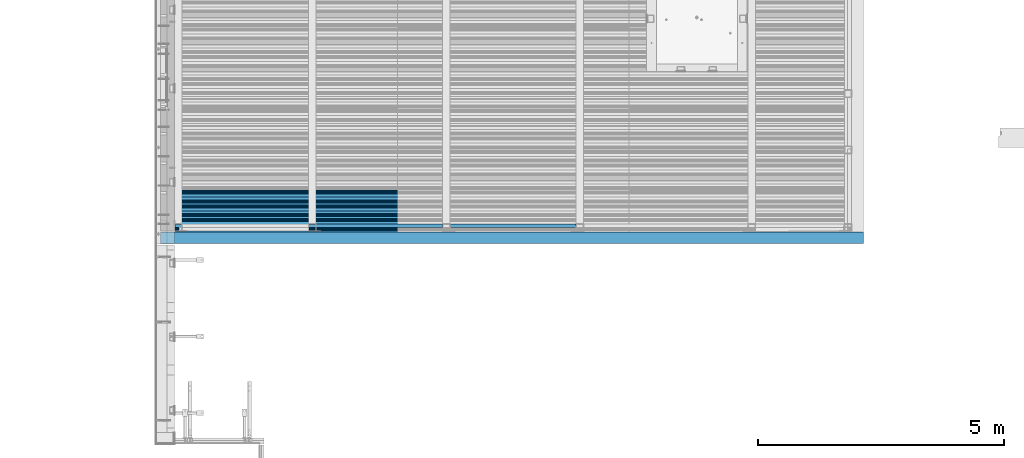
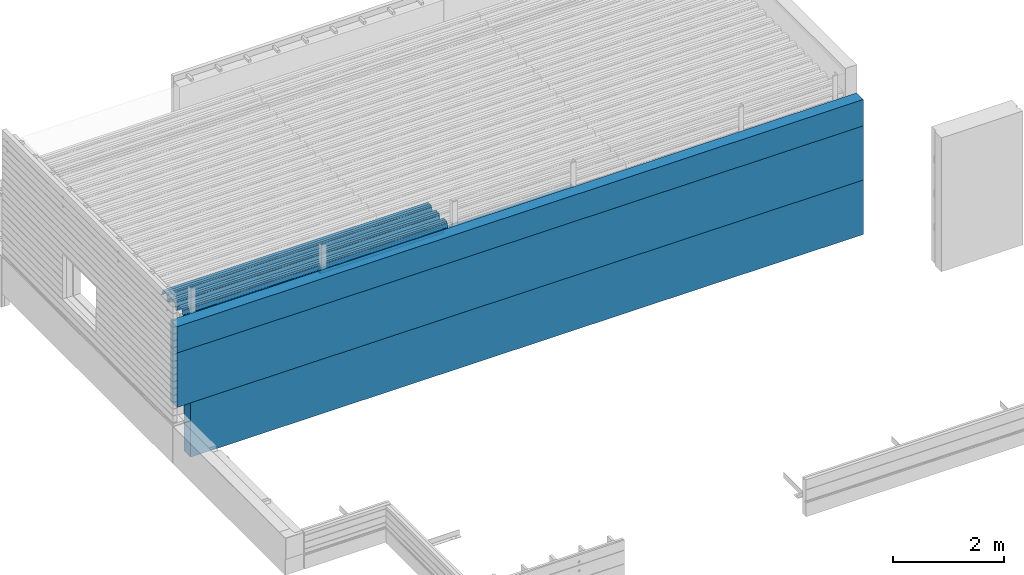
# One storey, part 18 of 153: 6 beams, 6 elements without a shape of their own.
"""IFC2X3 building model written with IfcOpenShell, lengths in millimetres."""

from ifc_helpers import new_model, si_unit, frame, origin_with_axes, place, context, subcontext, project, spatial, faceted_brep, material, type_object, element, aggregate, save


model = new_model("IFC2X3")

# Units and contexts
model_context = context("Model", 3, precision=1e-05, world=origin_with_axes())
body_context = subcontext(model_context, "Body", "Model", "MODEL_VIEW")
ifc_project = project(units=[si_unit("LENGTHUNIT", "METRE", prefix="MILLI"), si_unit("AREAUNIT", "SQUARE_METRE"), si_unit("VOLUMEUNIT", "CUBIC_METRE"), si_unit("MASSUNIT", "GRAM", prefix="KILO"), si_unit("TIMEUNIT", "SECOND"), si_unit("PLANEANGLEUNIT", "RADIAN"), si_unit("SOLIDANGLEUNIT", "STERADIAN"), si_unit("THERMODYNAMICTEMPERATUREUNIT", "DEGREE_CELSIUS"), si_unit("LUMINOUSINTENSITYUNIT", "LUMEN")], contexts=[model_context])

# Site, building, storey
site_placement = place(None, origin_with_axes())
site = spatial("IfcSite", under=ifc_project, at=site_placement, CompositionType="ELEMENT")
building_placement = place(site_placement, origin_with_axes())
building = spatial("IfcBuilding", under=site, at=building_placement, CompositionType="ELEMENT")
storey_placement = place(building_placement, origin_with_axes())
storey = spatial("IfcBuildingStorey", under=building, at=storey_placement, Name="8", CompositionType="ELEMENT", Elevation=0.0)

# Assembly, beam
assembly_1_placement = place(storey_placement, origin_with_axes())
assembly_1 = element("IfcElementAssembly", 1, at=assembly_1_placement, inside=storey, Name="Steel Assembly", AssemblyPlace="NOTDEFINED", PredefinedType="RIGID_FRAME")
ifc_material_1 = material(Name="STEEL/S355J2")
beam_type_1 = type_object("IfcBeamType", Name="80X80X4", PredefinedType="NOTDEFINED")
beam_1_placement = place(assembly_1_placement, frame((13610.0, 15090.0, 105625.0), z_axis=(0.0, 0.0, 1.0), x_axis=(1.0, 0.0, 0.0)))
beam_1 = element("IfcBeam", 2, at=beam_1_placement, type_object=beam_type_1, material=ifc_material_1, ObjectType="80X80X4", context=body_context, shape_type="Brep", body=[
    faceted_brep([(0.0, 36.0, -36.0), (0.0, -36.0, -36.0), (2567.0, -36.0, -36.0), (2567.0, 36.0, -36.0), (0.0, -36.0, 36.0), (2567.0, -36.0, 36.0), (0.0, 36.0, 36.0), (2567.0, 36.0, 36.0), (0.0, 40.0, -40.0), (0.0, 40.0, 40.0), (2567.0, 40.0, 40.0), (2567.0, 40.0, -40.0), (0.0, -40.0, 40.0), (2567.0, -40.0, 40.0), (0.0, -40.0, -40.0), (2567.0, -40.0, -40.0)], [[[0, 1, 2, 3]], [[1, 4, 5, 2]], [[4, 6, 7, 5]], [[6, 0, 3, 7]], [[8, 9, 10, 11]], [[9, 12, 13, 10]], [[12, 14, 15, 13]], [[14, 8, 11, 15]], [[13, 15, 11, 10], [5, 7, 3, 2]], [[14, 12, 9, 8], [6, 4, 1, 0]]]),
])
aggregate(assembly_1, [beam_1])

assembly_2_placement = place(storey_placement, origin_with_axes())
assembly_2 = element("IfcElementAssembly", 3, at=assembly_2_placement, inside=storey, Name="Steel Assembly", AssemblyPlace="NOTDEFINED", PredefinedType="RIGID_FRAME")
beam_2_placement = place(assembly_2_placement, frame((10880.0, 15090.0, 105625.0), z_axis=(0.0, 0.0, 1.0), x_axis=(1.0, 0.0, 0.0)))
beam_2 = element("IfcBeam", 4, at=beam_2_placement, type_object=beam_type_1, material=ifc_material_1, ObjectType="80X80X4", context=body_context, shape_type="Brep", body=[
    faceted_brep([(0.0, 36.0, -36.0), (0.0, -36.0, -36.0), (2580.0, -36.0, -36.0), (2580.0, 36.0, -36.0), (0.0, -36.0, 36.0), (2580.0, -36.0, 36.0), (0.0, 36.0, 36.0), (2580.0, 36.0, 36.0), (0.0, 40.0, -40.0), (0.0, 40.0, 40.0), (2580.0, 40.0, 40.0), (2580.0, 40.0, -40.0), (0.0, -40.0, 40.0), (2580.0, -40.0, 40.0), (0.0, -40.0, -40.0), (2580.0, -40.0, -40.0)], [[[0, 1, 2, 3]], [[1, 4, 5, 2]], [[4, 6, 7, 5]], [[6, 0, 3, 7]], [[8, 9, 10, 11]], [[9, 12, 13, 10]], [[12, 14, 15, 13]], [[14, 8, 11, 15]], [[13, 15, 11, 10], [5, 7, 3, 2]], [[14, 12, 9, 8], [6, 4, 1, 0]]]),
])
aggregate(assembly_2, [beam_2])

assembly_3_placement = place(storey_placement, origin_with_axes())
assembly_3 = element("IfcElementAssembly", 5, at=assembly_3_placement, inside=storey, Name="Steel Assembly", AssemblyPlace="NOTDEFINED", PredefinedType="RIGID_FRAME")
beam_type_2 = type_object("IfcBeamType", Name="W", PredefinedType="NOTDEFINED")
beam_3_placement = place(assembly_3_placement, frame((13534.9999999929, 15385.2090542281, 105749.900488359), z_axis=(0.0, -0.0124990270013869, 0.999921884110963), x_axis=(-1.0, 3.00000001838171e-08, 0.0)))
beam_3 = element("IfcBeam", 6, at=beam_3_placement, type_object=beam_type_2, material=ifc_material_1, ObjectType="W", context=body_context, shape_type="Brep", body=[
    faceted_brep([(0.0, -412.839996337891, -77.0100021362159), (0.0, -409.160003662109, -77.0100021362014), (5530.0, -409.160003662109, -77.0100021362014), (5530.0, -412.839996337891, -77.0100021362159), (0.0, -408.070007324222, -73.4800033569045), (5530.0, -408.070007324222, -73.4800033569045), (0.0, -400.339996337894, -48.0600013732619), (5530.0, -400.339996337894, -48.0600013732619), (0.0, -399.459991455082, -46.5600013732619), (5530.0, -399.459991455082, -46.5600013732619), (0.0, -390.329986572269, -36.5499992370314), (5530.0, -390.329986572269, -36.5499992370314), (0.0, -389.19000244141, -34.6300010680861), (5530.0, -389.19000244141, -34.6300010680861), (0.0, -367.820007324222, 35.3400001526024), (5530.0, -367.820007324222, 35.3400001526024), (0.0, -366.989990234379, 36.8499984741502), (5530.0, -366.989990234379, 36.8499984741502), (0.0, -357.809997558597, 46.8600006103807), (5530.0, -357.809997558597, 46.8600006103807), (0.0, -356.720001220707, 48.7700004577782), (5530.0, -356.720001220707, 48.7700004577782), (0.0, -349.309997558594, 73.1500015258935), (5530.0, -349.309997558594, 73.1500015258935), (0.0, -347.850006103516, 75.2300033569481), (5530.0, -347.850006103516, 75.2300033569481), (0.0, -345.470001220707, 76.010002136245), (5530.0, -345.470001220707, 76.010002136245), (0.0, -305.480010986332, 76.010002136245), (5530.0, -305.480010986332, 76.010002136245), (0.0, -304.279998779301, 75.8000030517578), (5530.0, -304.279998779301, 75.8000030517578), (0.0, -291.679992675785, 71.6999969482567), (5530.0, -291.679992675785, 71.6999969482567), (0.0, -290.179992675789, 71.2300033569481), (5530.0, -290.179992675789, 71.2300033569481), (0.0, -288.720001220707, 71.6999969482567), (5530.0, -288.720001220707, 71.6999969482567), (0.0, -276.119995117191, 75.8000030517869), (5530.0, -276.119995117191, 75.8000030517869), (0.0, -274.929992675785, 76.010002136245), (5530.0, -274.929992675785, 76.010002136245), (0.0, -234.94000244141, 76.010002136245), (5530.0, -234.94000244141, 76.010002136245), (0.0, -232.550003051758, 75.2300033569627), (5530.0, -232.550003051758, 75.2300033569627), (0.0, -231.100006103519, 73.1500015258935), (5530.0, -231.100006103519, 73.1500015258935), (0.0, -223.679992675785, 48.7700004577782), (5530.0, -223.679992675785, 48.7700004577782), (0.0, -222.589996337894, 46.8600006103661), (5530.0, -222.589996337894, 46.8600006103661), (0.0, -213.410003662113, 36.8499984741502), (5530.0, -213.410003662113, 36.8499984741502), (0.0, -212.529998779301, 35.3400001526024), (5530.0, -212.529998779301, 35.3400001526024), (0.0, -191.160003662109, -34.6300010681007), (5530.0, -191.160003662109, -34.6300010681007), (0.0, -190.070007324222, -36.5499992370605), (5530.0, -190.070007324222, -36.5499992370605), (0.0, -180.940002441406, -46.560001373291), (5530.0, -180.940002441406, -46.560001373291), (0.0, -180.059997558597, -48.0600013732619), (5530.0, -180.059997558597, -48.0600013732619), (0.0, -172.330001831055, -73.480003356919), (5530.0, -172.330001831055, -73.480003356919), (0.0, -171.240005493168, -77.0100021362159), (5530.0, -171.240005493168, -77.0100021362159), (0.0, -129.330001831062, -77.0100021362014), (5530.0, -129.330001831062, -77.0100021362014), (0.0, -128.300003051761, -73.480003356919), (5530.0, -128.300003051761, -73.480003356919), (0.0, -120.51999664307, -48.0600013732765), (5530.0, -120.51999664307, -48.0600013732765), (0.0, -119.629997253418, -46.5600013732765), (5530.0, -119.629997253418, -46.5600013732765), (0.0, -110.500000000004, -36.5499992370314), (5530.0, -110.500000000004, -36.5499992370314), (0.0, -109.419998168949, -34.6300010680861), (5530.0, -109.419998168949, -34.6300010680861), (0.0, -88.0500030517615, 35.3400001526024), (5530.0, -88.0500030517615, 35.3400001526024), (0.0, -87.160003662113, 36.8499984741356), (5530.0, -87.160003662113, 36.8499984741356), (0.0, -78.0400009155273, 46.8600006103807), (5530.0, -78.0400009155273, 46.8600006103807), (0.0, -76.8899993896557, 48.7700004577782), (5530.0, -76.8899993896557, 48.7700004577782), (0.0, -69.4800033569336, 73.1500015258935), (5530.0, -69.4800033569336, 73.1500015258935), (0.0, -68.0299987793042, 75.2300033569336), (5530.0, -68.0299987793042, 75.2300033569336), (0.0, -65.6399993896521, 76.010002136245), (5530.0, -65.6399993896521, 76.010002136245), (0.0, -25.6499996185375, 76.0100021362596), (5530.0, -25.6499996185375, 76.0100021362596), (0.0, -24.5100002288891, 75.8000030517724), (5530.0, -24.5100002288891, 75.8000030517724), (0.0, -11.8500003814697, 71.6999969482567), (5530.0, -11.8500003814697, 71.6999969482567), (0.0, -10.3999996185339, 71.2300033569481), (5530.0, -10.3999996185339, 71.2300033569481), (0.0, -8.89999961853391, 71.6999969482567), (5530.0, -8.89999961853391, 71.6999969482567), (0.0, 3.71000003814333, 75.8000030517724), (5530.0, 3.71000003814333, 75.8000030517724), (0.0, 4.90000009536379, 76.0100021362596), (5530.0, 4.90000009536379, 76.0100021362596), (0.0, 44.8899993896484, 76.010002136245), (5530.0, 44.8899993896484, 76.010002136245), (0.0, 47.2799987792932, 75.2300033569481), (5530.0, 47.2799987792932, 75.2300033569481), (0.0, 48.6800003051721, 73.1500015258935), (5530.0, 48.6800003051721, 73.1500015258935), (0.0, 56.1500015258753, 48.7700004577782), (5530.0, 56.1500015258753, 48.7700004577782), (0.0, 57.2400016784632, 46.8600006103807), (5530.0, 57.2400016784632, 46.8600006103807), (0.0, 66.3700027465784, 36.8499984741211), (5530.0, 66.3700027465784, 36.8499984741211), (0.0, 67.2499999999964, 35.3400001526024), (5530.0, 67.2499999999964, 35.3400001526024), (0.0, 88.6200027465748, -34.6300010681007), (5530.0, 88.6200027465748, -34.6300010681007), (0.0, 89.709999084469, -36.549999237046), (5530.0, 89.709999084469, -36.549999237046), (0.0, 98.8899993896412, -46.5600013732765), (5530.0, 98.8899993896412, -46.5600013732765), (0.0, 99.7699966430628, -48.0600013732765), (5530.0, 99.7699966430628, -48.0600013732765), (0.0, 107.499999999996, -73.4800033569336), (5530.0, 107.499999999996, -73.4800033569336), (0.0, 108.589996337887, -77.0100021362014), (5530.0, 108.589996337887, -77.0100021362014), (0.0, 112.269996643063, -77.0100021362159), (5530.0, 112.269996643063, -77.0100021362159), (0.0, 146.759994506836, -77.0100021362159), (5530.0, 146.759994506836, -77.0100021362159), (0.0, 150.440002441403, -77.0100021362159), (5530.0, 150.440002441403, -77.0100021362159), (0.0, 151.529998779297, -73.480003356919), (5530.0, 151.529998779297, -73.480003356919), (0.0, 159.30999755859, -48.0600013732765), (5530.0, 159.30999755859, -48.0600013732765), (0.0, 160.190002441406, -46.5600013732619), (5530.0, 160.190002441406, -46.5600013732619), (0.0, 169.320007324215, -36.549999237046), (5530.0, 169.320007324215, -36.549999237046), (0.0, 170.410003662106, -34.6300010680861), (5530.0, 170.410003662106, -34.6300010680861), (0.0, 191.779998779293, 35.3400001526024), (5530.0, 191.779998779293, 35.3400001526024), (0.0, 192.660003662109, 36.8499984741502), (5530.0, 192.660003662109, 36.8499984741502), (0.0, 201.789993286129, 46.8600006103661), (5530.0, 201.789993286129, 46.8600006103661), (0.0, 202.880004882809, 48.7700004577637), (5530.0, 202.880004882809, 48.7700004577637), (0.0, 210.350006103512, 73.150001525908), (5530.0, 210.350006103512, 73.150001525908), (0.0, 211.800003051754, 75.2300033569481), (5530.0, 211.800003051754, 75.2300033569481), (0.0, 214.190002441406, 76.010002136245), (5530.0, 214.190002441406, 76.010002136245), (0.0, 254.179992675778, 76.010002136245), (5530.0, 254.179992675778, 76.010002136245), (0.0, 255.320007324215, 75.8000030517869), (5530.0, 255.320007324215, 75.8000030517869), (0.0, 267.980010986324, 71.6999969482713), (5530.0, 267.980010986324, 71.6999969482713), (0.0, 269.429992675778, 71.2300033569481), (5530.0, 269.429992675778, 71.2300033569481), (0.0, 270.880004882809, 71.6999969482567), (5530.0, 270.880004882809, 71.6999969482567), (0.0, 283.540008544918, 75.8000030517869), (5530.0, 283.540008544918, 75.8000030517869), (0.0, 284.679992675778, 76.010002136245), (5530.0, 284.679992675778, 76.010002136245), (0.0, 324.670013427731, 76.010002136245), (5530.0, 324.670013427731, 76.010002136245), (0.0, 327.049987792969, 75.2300033569627), (5530.0, 327.049987792969, 75.2300033569627), (0.0, 328.510009765625, 73.1500015258789), (5530.0, 328.510009765625, 73.1500015258789), (0.0, 335.980010986324, 48.7700004577782), (5530.0, 335.980010986324, 48.7700004577782), (0.0, 337.05999755859, 46.8600006103661), (5530.0, 337.05999755859, 46.8600006103661), (0.0, 346.190002441399, 36.8499984741356), (5530.0, 346.190002441399, 36.8499984741356), (0.0, 347.079986572266, 35.3400001526024), (5530.0, 347.079986572266, 35.3400001526024), (0.0, 368.450012207028, -34.6300010680861), (5530.0, 368.450012207028, -34.6300010680861), (0.0, 369.529998779293, -36.5499992370314), (5530.0, 369.529998779293, -36.5499992370314), (0.0, 378.660003662106, -46.5600013732619), (5530.0, 378.660003662106, -46.5600013732619), (0.0, 379.540008544918, -48.0600013732619), (5530.0, 379.540008544918, -48.0600013732619), (0.0, 387.329986572262, -73.480003356919), (5530.0, 387.329986572262, -73.480003356919), (0.0, 388.410003662109, -77.0100021362159), (5530.0, 388.410003662109, -77.0100021362159), (0.0, 392.100006103512, -77.0100021362159), (5530.0, 392.100006103512, -77.0100021362159), (0.0, 426.589996337887, -77.0100021362159), (5530.0, 426.589996337887, -77.0100021362159), (0.0, 430.269989013668, -77.0100021362159), (5530.0, 430.269989013668, -77.0100021362159), (0.0, 431.359985351559, -73.4800033569045), (5530.0, 431.359985351559, -73.4800033569045), (0.0, 433.179992675778, -67.5699996948097), (5530.0, 433.179992675778, -67.5699996948097), (0.0, 432.220001220699, -67.2699966430373), (5530.0, 432.220001220699, -67.2699966430373), (0.0, 430.410003662106, -73.1800003051612), (5530.0, 430.410003662106, -73.1800003051612), (0.0, 429.529998779293, -76.0100021362159), (5530.0, 429.529998779293, -76.0100021362159), (0.0, 426.589996337891, -76.0100021362159), (5530.0, 426.589996337891, -76.0100021362159), (0.0, 392.100006103512, -76.0100021362159), (5530.0, 392.100006103512, -76.0100021362159), (0.0, 389.149993896481, -76.0100021362014), (5530.0, 389.149993896481, -76.0100021362014), (0.0, 388.279998779293, -73.1800003051467), (5530.0, 388.279998779293, -73.1800003051467), (0.0, 380.470001220699, -47.659999847383), (5530.0, 380.470001220699, -47.659999847383), (0.0, 379.470001220699, -45.9599990844436), (5530.0, 379.470001220699, -45.9599990844436), (0.0, 370.350006103512, -35.9599990844581), (5530.0, 370.350006103512, -35.9599990844581), (0.0, 369.369995117184, -34.2299995422218), (5530.0, 369.369995117184, -34.2299995422218), (0.0, 347.999999999996, 35.7500000000146), (5530.0, 347.999999999996, 35.7500000000146), (0.0, 346.999999999996, 37.4399986267235), (5530.0, 346.999999999996, 37.4399986267235), (0.0, 337.880004882809, 47.450000762954), (5530.0, 337.880004882809, 47.450000762954), (0.0, 336.899993896481, 49.1699981689453), (5530.0, 336.899993896481, 49.1699981689453), (0.0, 329.420013427731, 73.5999984741356), (5530.0, 329.420013427731, 73.5999984741356), (0.0, 327.679992675781, 76.0699996948533), (5530.0, 327.679992675781, 76.0699996948533), (0.0, 324.829986572262, 77.010002136245), (5530.0, 324.829986572262, 77.010002136245), (0.0, 284.589996337887, 77.010002136245), (5530.0, 284.589996337887, 77.010002136245), (0.0, 283.290008544922, 76.769996643081), (5530.0, 283.290008544922, 76.769996643081), (0.0, 270.570007324215, 72.6500015258935), (5530.0, 270.570007324215, 72.6500015258935), (0.0, 269.429992675781, 72.2799987793114), (5530.0, 269.429992675781, 72.2799987793114), (0.0, 268.279998779293, 72.650001525908), (5530.0, 268.279998779293, 72.650001525908), (0.0, 255.570007324219, 76.769996643081), (5530.0, 255.570007324219, 76.769996643081), (0.0, 254.270004272461, 77.0100021362596), (5530.0, 254.270004272461, 77.0100021362596), (0.0, 214.029998779293, 77.0100021362596), (5530.0, 214.029998779293, 77.0100021362596), (0.0, 211.179992675781, 76.0699996948388), (5530.0, 211.179992675781, 76.0699996948388), (0.0, 209.440002441403, 73.5999984741356), (5530.0, 209.440002441403, 73.5999984741356), (0.0, 201.960006713864, 49.1699981689599), (5530.0, 201.960006713864, 49.1699981689599), (0.0, 200.979995727532, 47.450000762954), (5530.0, 200.979995727532, 47.450000762954), (0.0, 191.850006103508, 37.4399986267235), (5530.0, 191.850006103508, 37.4399986267235), (0.0, 190.860000610352, 35.7500000000146), (5530.0, 190.860000610352, 35.7500000000146), (0.0, 169.49000549316, -34.2299995422218), (5530.0, 169.49000549316, -34.2299995422218), (0.0, 168.509994506832, -35.9599990844581), (5530.0, 168.509994506832, -35.9599990844581), (0.0, 159.380004882805, -45.9599990844436), (5530.0, 159.380004882805, -45.9599990844436), (0.0, 158.389999389645, -47.6599998473976), (5530.0, 158.389999389645, -47.6599998473976), (0.0, 150.580001831051, -73.1800003051612), (5530.0, 150.580001831051, -73.1800003051612), (0.0, 149.710006713864, -76.0100021362159), (5530.0, 149.710006713864, -76.0100021362159), (0.0, 146.759994506836, -76.0100021362159), (5530.0, 146.759994506836, -76.0100021362159), (0.0, 112.269996643063, -76.0100021362159), (5530.0, 112.269996643063, -76.0100021362159), (0.0, 109.319999694821, -76.0100021362159), (5530.0, 109.319999694821, -76.0100021362159), (0.0, 108.449996948239, -73.1900024413917), (5530.0, 108.449996948239, -73.1900024413917), (0.0, 100.690002441406, -47.659999847383), (5530.0, 100.690002441406, -47.659999847383), (0.0, 99.6999969482386, -45.9599990844581), (5530.0, 99.6999969482386, -45.9599990844581), (0.0, 90.5199966430664, -35.9599990844581), (5530.0, 90.5199966430664, -35.9599990844581), (0.0, 89.5400009155273, -34.2299995422218), (5530.0, 89.5400009155273, -34.2299995422218), (0.0, 68.1699981689417, 35.7500000000146), (5530.0, 68.1699981689417, 35.7500000000146), (0.0, 67.1699981689417, 37.4399986267235), (5530.0, 67.1699981689417, 37.4399986267235), (0.0, 58.0499992370569, 47.4500007629686), (5530.0, 58.0499992370569, 47.4500007629686), (0.0, 57.0699996948206, 49.1699981689599), (5530.0, 57.0699996948206, 49.1699981689599), (0.0, 49.5900001525843, 73.5899963379052), (5530.0, 49.5900001525843, 73.5899963379052), (0.0, 47.9099998474085, 76.0699996948388), (5530.0, 47.9099998474085, 76.0699996948388), (0.0, 45.0499992370569, 77.010002136245), (5530.0, 45.0499992370569, 77.010002136245), (0.0, 4.82000017165774, 77.010002136245), (5530.0, 4.82000017165774, 77.010002136245), (0.0, 3.47000002860659, 76.7699966430955), (5530.0, 3.47000002860659, 76.7699966430955), (0.0, -9.19999980926514, 72.6500015258935), (5530.0, -9.19999980926514, 72.6500015258935), (0.0, -10.3900003433264, 72.2799987792969), (5530.0, -10.3900003433264, 72.2799987792969), (0.0, -11.5399999618567, 72.6500015258935), (5530.0, -11.5399999618567, 72.6500015258935), (0.0, -24.2600002288855, 76.769996643081), (5530.0, -24.2600002288855, 76.769996643081), (0.0, -25.559999465946, 77.0100021362596), (5530.0, -25.559999465946, 77.0100021362596), (0.0, -65.8000030517615, 77.0100021362596), (5530.0, -65.8000030517615, 77.0100021362596), (0.0, -68.6500015258862, 76.0699996948533), (5530.0, -68.6500015258862, 76.0699996948533), (0.0, -70.3899993896521, 73.5999984741356), (5530.0, -70.3899993896521, 73.5999984741356), (0.0, -77.8199996948242, 49.1800003051903), (5530.0, -77.8199996948242, 49.1800003051903), (0.0, -78.8399963378943, 47.450000762954), (5530.0, -78.8399963378943, 47.450000762954), (0.0, -87.9700012207031, 37.4399986267235), (5530.0, -87.9700012207031, 37.4399986267235), (0.0, -88.9700012207068, 35.7500000000146), (5530.0, -88.9700012207068, 35.7500000000146), (0.0, -110.339996337894, -34.2299995422218), (5530.0, -110.339996337894, -34.2299995422218), (0.0, -111.319999694828, -35.9599990844581), (5530.0, -111.319999694828, -35.9599990844581), (0.0, -120.440002441406, -45.9599990844436), (5530.0, -120.440002441406, -45.9599990844436), (0.0, -121.44000244141, -47.6599998473976), (5530.0, -121.44000244141, -47.6599998473976), (0.0, -129.250000000004, -73.1900024413771), (5530.0, -129.250000000004, -73.1900024413771), (0.0, -130.080001831062, -76.0100021362159), (5530.0, -130.080001831062, -76.0100021362159), (0.0, -170.5, -76.0100021362014), (5530.0, -170.5, -76.0100021362014), (0.0, -171.380004882816, -73.1900024413917), (5530.0, -171.380004882816, -73.1900024413917), (0.0, -179.139999389652, -47.6599998473976), (5530.0, -179.139999389652, -47.6599998473976), (0.0, -180.130004882816, -45.9599990844581), (5530.0, -180.130004882816, -45.9599990844581), (0.0, -189.259994506836, -35.9599990844581), (5530.0, -189.259994506836, -35.9599990844581), (0.0, -190.240005493168, -34.2299995422218), (5530.0, -190.240005493168, -34.2299995422218), (0.0, -211.610000610355, 35.7500000000146), (5530.0, -211.610000610355, 35.7500000000146), (0.0, -212.600006103519, 37.4399986267381), (5530.0, -212.600006103519, 37.4399986267381), (0.0, -221.779998779301, 47.450000762954), (5530.0, -221.779998779301, 47.450000762954), (0.0, -222.75999450684, 49.1699981689599), (5530.0, -222.75999450684, 49.1699981689599), (0.0, -230.190002441406, 73.5999984741356), (5530.0, -230.190002441406, 73.5999984741356), (0.0, -231.919998168945, 76.0699996948388), (5530.0, -231.919998168945, 76.0699996948388), (0.0, -234.779998779301, 77.010002136245), (5530.0, -234.779998779301, 77.010002136245), (0.0, -275.010009765629, 77.010002136245), (5530.0, -275.010009765629, 77.010002136245), (0.0, -276.359985351563, 76.769996643081), (5530.0, -276.359985351563, 76.769996643081), (0.0, -289.029998779297, 72.6500015258789), (5530.0, -289.029998779297, 72.6500015258789), (0.0, -290.179992675785, 72.2799987793114), (5530.0, -290.179992675785, 72.2799987793114), (0.0, -291.380004882816, 72.650001525908), (5530.0, -291.380004882816, 72.650001525908), (0.0, -304.040008544926, 76.769996643081), (5530.0, -304.040008544926, 76.769996643081), (0.0, -305.390014648441, 77.010002136245), (5530.0, -305.390014648441, 77.010002136245), (0.0, -345.63000488282, 77.0100021362596), (5530.0, -345.63000488282, 77.0100021362596), (0.0, -348.480010986332, 76.0699996948388), (5530.0, -348.480010986332, 76.0699996948388), (0.0, -350.220001220707, 73.5999984741356), (5530.0, -350.220001220707, 73.5999984741356), (0.0, -357.649993896492, 49.1699981689599), (5530.0, -357.649993896492, 49.1699981689599), (0.0, -358.63000488282, 47.450000762954), (5530.0, -358.63000488282, 47.450000762954), (0.0, -367.809997558594, 37.4300003051903), (5530.0, -367.809997558594, 37.4300003051903), (0.0, -368.750000000004, 35.7299995422654), (5530.0, -368.750000000004, 35.7299995422654), (0.0, -390.109985351566, -34.2200012207031), (5530.0, -390.109985351566, -34.2200012207031), (0.0, -391.140014648441, -35.9500007629249), (5530.0, -391.140014648441, -35.9500007629249), (0.0, -400.269989013676, -45.9599990844436), (5530.0, -400.269989013676, -45.9599990844436), (0.0, -401.269989013672, -47.6599998473976), (5530.0, -401.269989013672, -47.6599998473976), (0.0, -409.029998779297, -73.1900024413917), (5530.0, -409.029998779297, -73.1900024413917), (0.0, -409.899993896488, -76.0100021362159), (5530.0, -409.899993896488, -76.0100021362159), (0.0, -412.839996337891, -76.0100021362159), (5530.0, -412.839996337891, -76.0100021362159), (0.0, -433.179992675785, -76.0100021362159), (5530.0, -433.179992675785, -76.0100021362159), (0.0, -433.179992675785, -77.0100021362159), (5530.0, -433.179992675785, -77.0100021362159)], [[[0, 1, 2, 3]], [[1, 4, 5, 2]], [[4, 6, 7, 5]], [[6, 8, 9, 7]], [[8, 10, 11, 9]], [[10, 12, 13, 11]], [[12, 14, 15, 13]], [[14, 16, 17, 15]], [[16, 18, 19, 17]], [[18, 20, 21, 19]], [[20, 22, 23, 21]], [[22, 24, 25, 23]], [[24, 26, 27, 25]], [[26, 28, 29, 27]], [[28, 30, 31, 29]], [[30, 32, 33, 31]], [[32, 34, 35, 33]], [[34, 36, 37, 35]], [[36, 38, 39, 37]], [[38, 40, 41, 39]], [[40, 42, 43, 41]], [[42, 44, 45, 43]], [[44, 46, 47, 45]], [[46, 48, 49, 47]], [[48, 50, 51, 49]], [[50, 52, 53, 51]], [[52, 54, 55, 53]], [[54, 56, 57, 55]], [[56, 58, 59, 57]], [[58, 60, 61, 59]], [[60, 62, 63, 61]], [[62, 64, 65, 63]], [[64, 66, 67, 65]], [[66, 68, 69, 67]], [[68, 70, 71, 69]], [[70, 72, 73, 71]], [[72, 74, 75, 73]], [[74, 76, 77, 75]], [[76, 78, 79, 77]], [[78, 80, 81, 79]], [[80, 82, 83, 81]], [[82, 84, 85, 83]], [[84, 86, 87, 85]], [[86, 88, 89, 87]], [[88, 90, 91, 89]], [[90, 92, 93, 91]], [[92, 94, 95, 93]], [[94, 96, 97, 95]], [[96, 98, 99, 97]], [[98, 100, 101, 99]], [[100, 102, 103, 101]], [[102, 104, 105, 103]], [[104, 106, 107, 105]], [[106, 108, 109, 107]], [[108, 110, 111, 109]], [[110, 112, 113, 111]], [[112, 114, 115, 113]], [[114, 116, 117, 115]], [[116, 118, 119, 117]], [[118, 120, 121, 119]], [[120, 122, 123, 121]], [[122, 124, 125, 123]], [[124, 126, 127, 125]], [[126, 128, 129, 127]], [[128, 130, 131, 129]], [[130, 132, 133, 131]], [[132, 134, 135, 133]], [[134, 136, 137, 135]], [[136, 138, 139, 137]], [[138, 140, 141, 139]], [[140, 142, 143, 141]], [[142, 144, 145, 143]], [[144, 146, 147, 145]], [[146, 148, 149, 147]], [[148, 150, 151, 149]], [[150, 152, 153, 151]], [[152, 154, 155, 153]], [[154, 156, 157, 155]], [[156, 158, 159, 157]], [[158, 160, 161, 159]], [[160, 162, 163, 161]], [[162, 164, 165, 163]], [[164, 166, 167, 165]], [[166, 168, 169, 167]], [[168, 170, 171, 169]], [[170, 172, 173, 171]], [[172, 174, 175, 173]], [[174, 176, 177, 175]], [[176, 178, 179, 177]], [[178, 180, 181, 179]], [[180, 182, 183, 181]], [[182, 184, 185, 183]], [[184, 186, 187, 185]], [[186, 188, 189, 187]], [[188, 190, 191, 189]], [[190, 192, 193, 191]], [[192, 194, 195, 193]], [[194, 196, 197, 195]], [[196, 198, 199, 197]], [[198, 200, 201, 199]], [[200, 202, 203, 201]], [[202, 204, 205, 203]], [[204, 206, 207, 205]], [[206, 208, 209, 207]], [[208, 210, 211, 209]], [[210, 212, 213, 211]], [[212, 214, 215, 213]], [[214, 216, 217, 215]], [[216, 218, 219, 217]], [[218, 220, 221, 219]], [[220, 222, 223, 221]], [[222, 224, 225, 223]], [[224, 226, 227, 225]], [[226, 228, 229, 227]], [[228, 230, 231, 229]], [[230, 232, 233, 231]], [[232, 234, 235, 233]], [[234, 236, 237, 235]], [[236, 238, 239, 237]], [[238, 240, 241, 239]], [[240, 242, 243, 241]], [[242, 244, 245, 243]], [[244, 246, 247, 245]], [[246, 248, 249, 247]], [[248, 250, 251, 249]], [[250, 252, 253, 251]], [[252, 254, 255, 253]], [[254, 256, 257, 255]], [[256, 258, 259, 257]], [[258, 260, 261, 259]], [[260, 262, 263, 261]], [[262, 264, 265, 263]], [[264, 266, 267, 265]], [[266, 268, 269, 267]], [[268, 270, 271, 269]], [[270, 272, 273, 271]], [[272, 274, 275, 273]], [[274, 276, 277, 275]], [[276, 278, 279, 277]], [[278, 280, 281, 279]], [[280, 282, 283, 281]], [[282, 284, 285, 283]], [[284, 286, 287, 285]], [[286, 288, 289, 287]], [[288, 290, 291, 289]], [[290, 292, 293, 291]], [[292, 294, 295, 293]], [[294, 296, 297, 295]], [[296, 298, 299, 297]], [[298, 300, 301, 299]], [[300, 302, 303, 301]], [[302, 304, 305, 303]], [[304, 306, 307, 305]], [[306, 308, 309, 307]], [[308, 310, 311, 309]], [[310, 312, 313, 311]], [[312, 314, 315, 313]], [[314, 316, 317, 315]], [[316, 318, 319, 317]], [[318, 320, 321, 319]], [[320, 322, 323, 321]], [[322, 324, 325, 323]], [[324, 326, 327, 325]], [[326, 328, 329, 327]], [[328, 330, 331, 329]], [[330, 332, 333, 331]], [[332, 334, 335, 333]], [[334, 336, 337, 335]], [[336, 338, 339, 337]], [[338, 340, 341, 339]], [[340, 342, 343, 341]], [[342, 344, 345, 343]], [[344, 346, 347, 345]], [[346, 348, 349, 347]], [[348, 350, 351, 349]], [[350, 352, 353, 351]], [[352, 354, 355, 353]], [[354, 356, 357, 355]], [[356, 358, 359, 357]], [[358, 360, 361, 359]], [[360, 362, 363, 361]], [[362, 364, 365, 363]], [[364, 366, 367, 365]], [[366, 368, 369, 367]], [[368, 370, 371, 369]], [[370, 372, 373, 371]], [[372, 374, 375, 373]], [[374, 376, 377, 375]], [[376, 378, 379, 377]], [[378, 380, 381, 379]], [[380, 382, 383, 381]], [[382, 384, 385, 383]], [[384, 386, 387, 385]], [[386, 388, 389, 387]], [[388, 390, 391, 389]], [[390, 392, 393, 391]], [[392, 394, 395, 393]], [[394, 396, 397, 395]], [[396, 398, 399, 397]], [[398, 400, 401, 399]], [[400, 402, 403, 401]], [[402, 404, 405, 403]], [[404, 406, 407, 405]], [[406, 408, 409, 407]], [[408, 410, 411, 409]], [[410, 412, 413, 411]], [[412, 414, 415, 413]], [[414, 416, 417, 415]], [[416, 418, 419, 417]], [[418, 420, 421, 419]], [[420, 422, 423, 421]], [[422, 424, 425, 423]], [[424, 426, 427, 425]], [[426, 428, 429, 427]], [[428, 430, 431, 429]], [[430, 0, 3, 431]], [[5, 7, 9, 11, 13, 15, 17, 19, 21, 23, 25, 27, 29, 31, 33, 35, 37, 39, 41, 43, 45, 47, 49, 51, 53, 55, 57, 59, 61, 63, 65, 67, 69, 71, 73, 75, 77, 79, 81, 83, 85, 87, 89, 91, 93, 95, 97, 99, 101, 103, 105, 107, 109, 111, 113, 115, 117, 119, 121, 123, 125, 127, 129, 131, 133, 135, 137, 139, 141, 143, 145, 147, 149, 151, 153, 155, 157, 159, 161, 163, 165, 167, 169, 171, 173, 175, 177, 179, 181, 183, 185, 187, 189, 191, 193, 195, 197, 199, 201, 203, 205, 207, 209, 211, 213, 215, 217, 219, 221, 223, 225, 227, 229, 231, 233, 235, 237, 239, 241, 243, 245, 247, 249, 251, 253, 255, 257, 259, 261, 263, 265, 267, 269, 271, 273, 275, 277, 279, 281, 283, 285, 287, 289, 291, 293, 295, 297, 299, 301, 303, 305, 307, 309, 311, 313, 315, 317, 319, 321, 323, 325, 327, 329, 331, 333, 335, 337, 339, 341, 343, 345, 347, 349, 351, 353, 355, 357, 359, 361, 363, 365, 367, 369, 371, 373, 375, 377, 379, 381, 383, 385, 387, 389, 391, 393, 395, 397, 399, 401, 403, 405, 407, 409, 411, 413, 415, 417, 419, 421, 423, 425, 427, 429, 431, 3, 2]], [[430, 428, 426, 424, 422, 420, 418, 416, 414, 412, 410, 408, 406, 404, 402, 400, 398, 396, 394, 392, 390, 388, 386, 384, 382, 380, 378, 376, 374, 372, 370, 368, 366, 364, 362, 360, 358, 356, 354, 352, 350, 348, 346, 344, 342, 340, 338, 336, 334, 332, 330, 328, 326, 324, 322, 320, 318, 316, 314, 312, 310, 308, 306, 304, 302, 300, 298, 296, 294, 292, 290, 288, 286, 284, 282, 280, 278, 276, 274, 272, 270, 268, 266, 264, 262, 260, 258, 256, 254, 252, 250, 248, 246, 244, 242, 240, 238, 236, 234, 232, 230, 228, 226, 224, 222, 220, 218, 216, 214, 212, 210, 208, 206, 204, 202, 200, 198, 196, 194, 192, 190, 188, 186, 184, 182, 180, 178, 176, 174, 172, 170, 168, 166, 164, 162, 160, 158, 156, 154, 152, 150, 148, 146, 144, 142, 140, 138, 136, 134, 132, 130, 128, 126, 124, 122, 120, 118, 116, 114, 112, 110, 108, 106, 104, 102, 100, 98, 96, 94, 92, 90, 88, 86, 84, 82, 80, 78, 76, 74, 72, 70, 68, 66, 64, 62, 60, 58, 56, 54, 52, 50, 48, 46, 44, 42, 40, 38, 36, 34, 32, 30, 28, 26, 24, 22, 20, 18, 16, 14, 12, 10, 8, 6, 4, 1, 0]]]),
])
aggregate(assembly_3, [beam_3])

assembly_4_placement = place(storey_placement, origin_with_axes())
assembly_4 = element("IfcElementAssembly", 7, at=assembly_4_placement, inside=storey, Name="Steel Assembly", AssemblyPlace="NOTDEFINED", PredefinedType="NOTDEFINED")
ifc_material_2 = material()
beam_type_3 = type_object("IfcBeamType", PredefinedType="NOTDEFINED")
beam_4_placement = place(assembly_4_placement, frame((7714.99879520438, 14845.0025069363, 104550.0), z_axis=(0.0, 0.0, 1.0), x_axis=(1.0, 0.0, 0.0)))
beam_4 = element("IfcBeam", 8, at=beam_4_placement, type_object=beam_type_3, material=ifc_material_2, Name="SW", context=body_context, shape_type="Brep", body=[
    faceted_brep([(0.0, 120.0, -600.0), (0.0, 120.0, 600.0), (14312.0025634766, 120.0, 600.0), (14312.0025634766, 120.0, -600.0), (0.0, -120.0, 600.0), (14312.0025634766, -120.0, 600.0), (0.0, -120.0, -600.0), (14312.0025634766, -120.0, -600.0)], [[[0, 1, 2, 3]], [[1, 4, 5, 2]], [[4, 6, 7, 5]], [[6, 0, 3, 7]], [[5, 7, 3, 2]], [[6, 4, 1, 0]]]),
])
aggregate(assembly_4, [beam_4])

assembly_5_placement = place(storey_placement, origin_with_axes())
assembly_5 = element("IfcElementAssembly", 9, at=assembly_5_placement, inside=storey, Name="Steel Assembly", AssemblyPlace="NOTDEFINED", PredefinedType="NOTDEFINED")
beam_5_placement = place(assembly_5_placement, frame((7999.99879520438, 14845.0025069363, 103355.0), z_axis=(0.0, 0.0, 1.0), x_axis=(1.0, 0.0, 0.0)))
beam_5 = element("IfcBeam", 10, at=beam_5_placement, type_object=beam_type_3, material=ifc_material_2, Name="SW", context=body_context, shape_type="Brep", body=[
    faceted_brep([(0.0, 120.0, -600.0), (0.0, 120.0, 600.0), (14027.0025634766, 120.0, 600.0), (14027.0025634766, 120.0, -600.0), (0.0, -120.0, 600.0), (14027.0025634766, -120.0, 600.0), (0.0, -120.0, -600.0), (14027.0025634766, -120.0, -600.0)], [[[0, 1, 2, 3]], [[1, 4, 5, 2]], [[4, 6, 7, 5]], [[6, 0, 3, 7]], [[5, 7, 3, 2]], [[6, 4, 1, 0]]]),
])
aggregate(assembly_5, [beam_5])

assembly_6_placement = place(storey_placement, origin_with_axes())
assembly_6 = element("IfcElementAssembly", 11, at=assembly_6_placement, inside=storey, Name="Steel Assembly", AssemblyPlace="NOTDEFINED", PredefinedType="NOTDEFINED")
beam_type_4 = type_object("IfcBeamType", PredefinedType="NOTDEFINED")
beam_6_placement = place(assembly_6_placement, frame((7714.99879520438, 14845.0025069363, 105440.0), z_axis=(0.0, 0.0, 1.0), x_axis=(1.0, 0.0, 0.0)))
beam_6 = element("IfcBeam", 12, at=beam_6_placement, type_object=beam_type_4, material=ifc_material_2, Name="SW", context=body_context, shape_type="Brep", body=[
    faceted_brep([(0.0, 120.0, -290.0), (0.0, 120.0, 290.0), (14312.0025634766, 120.0, 290.0), (14312.0025634766, 120.0, -290.0), (0.0, -120.0, 290.0), (14312.0025634766, -120.0, 290.0), (0.0, -120.0, -290.0), (14312.0025634766, -120.0, -290.0)], [[[0, 1, 2, 3]], [[1, 4, 5, 2]], [[4, 6, 7, 5]], [[6, 0, 3, 7]], [[5, 7, 3, 2]], [[6, 4, 1, 0]]]),
])
aggregate(assembly_6, [beam_6])

save(model, "model.ifc")
